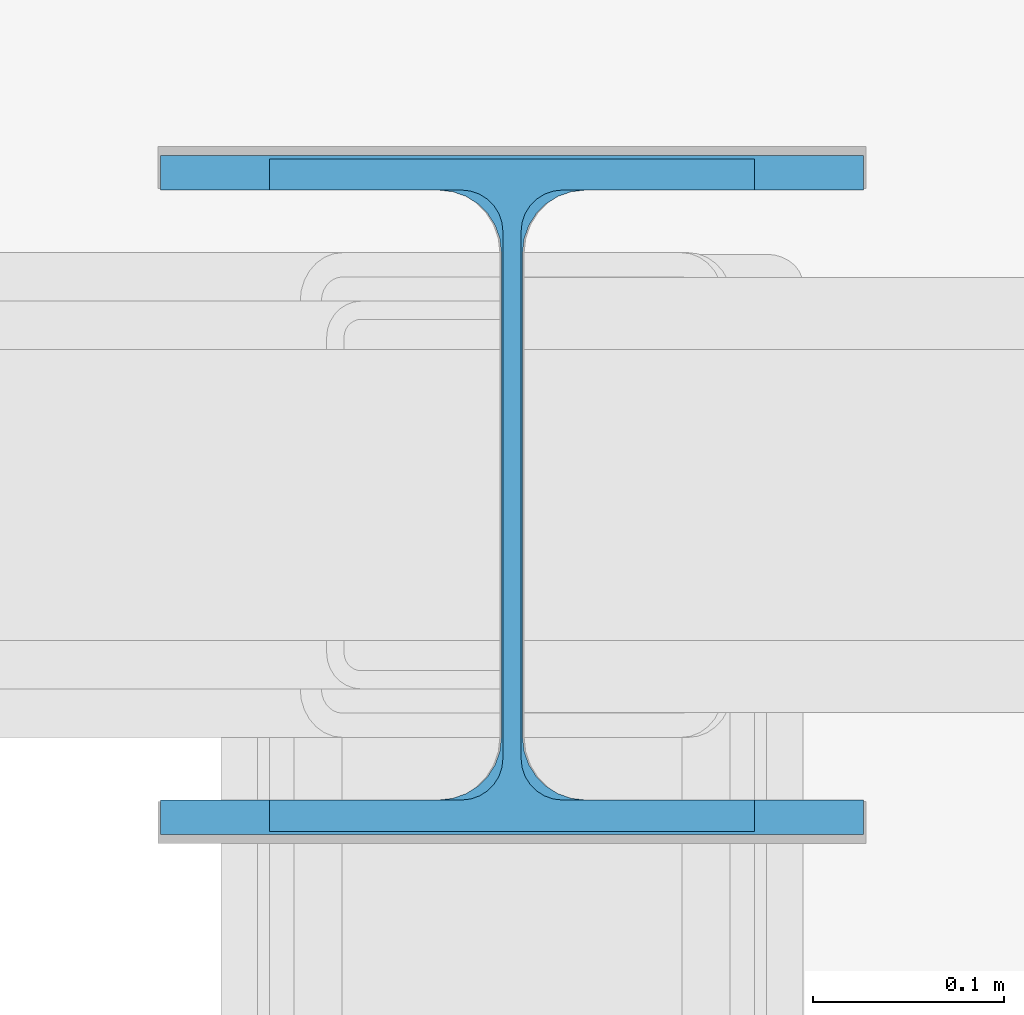
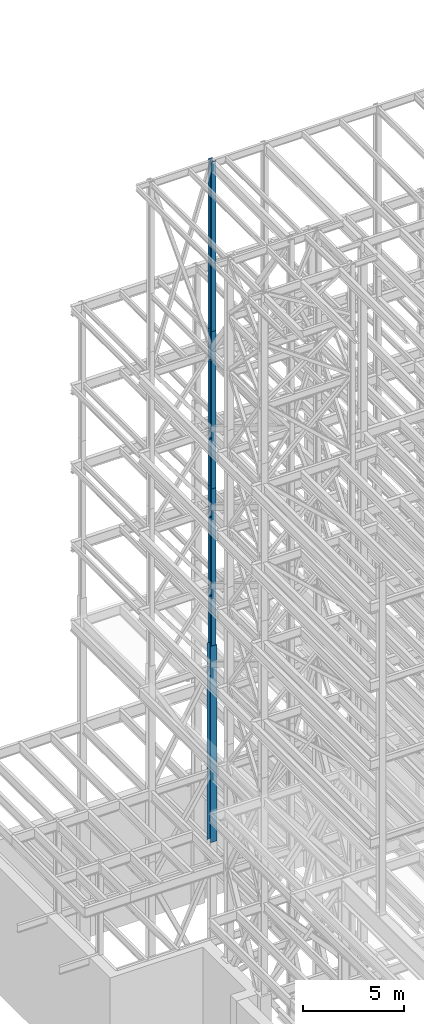
# One storey, part 54 of 150: 4 columns.
"""IFC2X3 building model written with IfcOpenShell, lengths in millimetres."""

from ifc_helpers import new_model, si_unit, frame, origin_with_axes, origin_2d_with_axis, place, context, subcontext, project, spatial, i_section, extrude, material, type_object, element, save


model = new_model("IFC2X3")

# Units and contexts
model_context = context("Model", 3, precision=1e-05, world=origin_with_axes())
body_context = subcontext(model_context, "Body", "Model", "MODEL_VIEW")
ifc_project = project(units=[si_unit("LENGTHUNIT", "METRE", prefix="MILLI"), si_unit("AREAUNIT", "SQUARE_METRE"), si_unit("VOLUMEUNIT", "CUBIC_METRE"), si_unit("MASSUNIT", "GRAM", prefix="KILO"), si_unit("TIMEUNIT", "SECOND"), si_unit("PLANEANGLEUNIT", "RADIAN"), si_unit("SOLIDANGLEUNIT", "STERADIAN"), si_unit("THERMODYNAMICTEMPERATUREUNIT", "DEGREE_CELSIUS"), si_unit("LUMINOUSINTENSITYUNIT", "LUMEN")], contexts=[model_context])

# Site, building, storey
site_placement = place(None, origin_with_axes())
site = spatial("IfcSite", under=ifc_project, at=site_placement, CompositionType="ELEMENT")
building_placement = place(site_placement, origin_with_axes())
building = spatial("IfcBuilding", under=site, at=building_placement, Name="Undefined", CompositionType="ELEMENT")
storey_placement = place(building_placement, origin_with_axes())
storey = spatial("IfcBuildingStorey", under=building, at=storey_placement, Name="Undefined", CompositionType="ELEMENT", Elevation=0.0)

# Columns
ifc_material = material(Name="STEEL/A992")
column_type_1 = type_object("IfcColumnType", Name="W14X61", PredefinedType="NOTDEFINED")
column_1_placement = place(storey_placement, frame((8788.39879604043, 32130.9992989538, 55702.2), z_axis=(0.0, 0.0, 1.0), x_axis=(1.0, 0.0, 0.0)))
element("IfcColumn", 1, at=column_1_placement, inside=storey, type_object=column_type_1, material=ifc_material, Name="COLUMN", ObjectType="W14X61", context=body_context, shape_type="SweptSolid", body=[
    extrude(i_section(OverallWidth=254.0, OverallDepth=352.425, WebThickness=9.5249, FlangeThickness=16.383, FilletRadius=21.717, at=origin_2d_with_axis()), frame((0.0, 0.0, 10210.8), z_axis=(0.0, 0.0, -1.0), x_axis=(-1.0, 0.0, 0.0)), (0.0, 0.0, 1.0), 10210.8),
])
for number, where, z_axis, x_axis, name in (
    (2, (8788.39879604043, 32130.9992989538, 46253.4), (0.0, 0.0, 1.0), (1.0, 0.0, 0.0), "COLUMN"),
    (3, (8788.39879604043, 32130.9992989538, 36804.6), (0.0, 0.0, 1.0), (1.0, 0.0, 0.0), "COLUMN"),
):
    element("IfcColumn", number, at=place(storey_placement, frame(where, z_axis=z_axis, x_axis=x_axis)), inside=storey, type_object=column_type_1, material=ifc_material, Name=name, ObjectType="W14X61", context=body_context, shape_type="SweptSolid", body=[
        extrude(i_section(OverallWidth=254.0, OverallDepth=352.425, WebThickness=9.5249, FlangeThickness=16.383, FilletRadius=21.717, at=origin_2d_with_axis()), frame((0.0, 0.0, 9448.8), z_axis=(0.0, 0.0, -1.0), x_axis=(-1.0, 0.0, 0.0)), (0.0, 0.0, 1.0), 9448.8),
    ])
column_type_2 = type_object("IfcColumnType", Name="W14X90", PredefinedType="NOTDEFINED")
column_2_placement = place(storey_placement, frame((8788.39879604043, 32130.9992989538, 24993.6), z_axis=(0.0, 0.0, 1.0), x_axis=(1.0, 0.0, 0.0)))
element("IfcColumn", 4, at=column_2_placement, inside=storey, type_object=column_type_2, material=ifc_material, Name="COLUMN", ObjectType="W14X90", context=body_context, shape_type="SweptSolid", body=[
    extrude(i_section(OverallWidth=368.3, OverallDepth=355.6, WebThickness=11.1125, FlangeThickness=18.034, FilletRadius=32.7659, at=origin_2d_with_axis()), frame((0.0, 0.0, 11811.0), z_axis=(0.0, 0.0, -1.0), x_axis=(-1.0, 0.0, 0.0)), (0.0, 0.0, 1.0), 11811.0),
])

save(model, "model.ifc")
